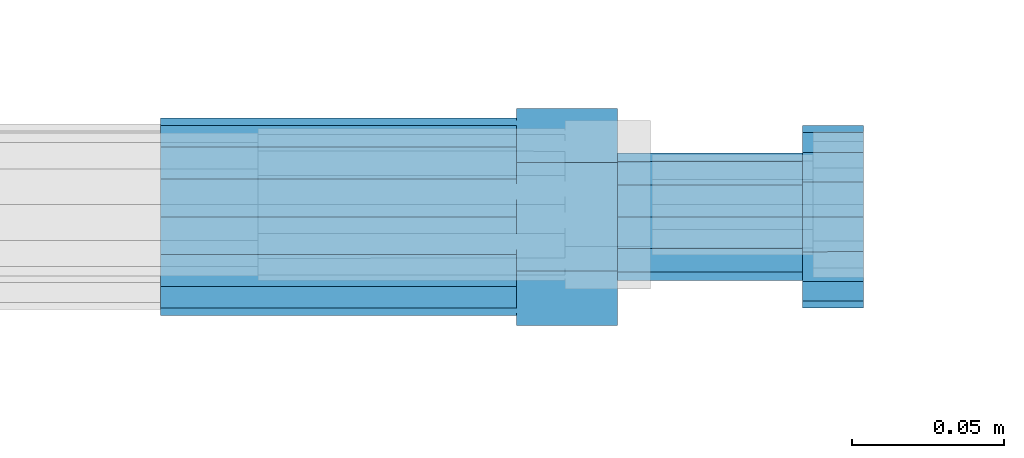
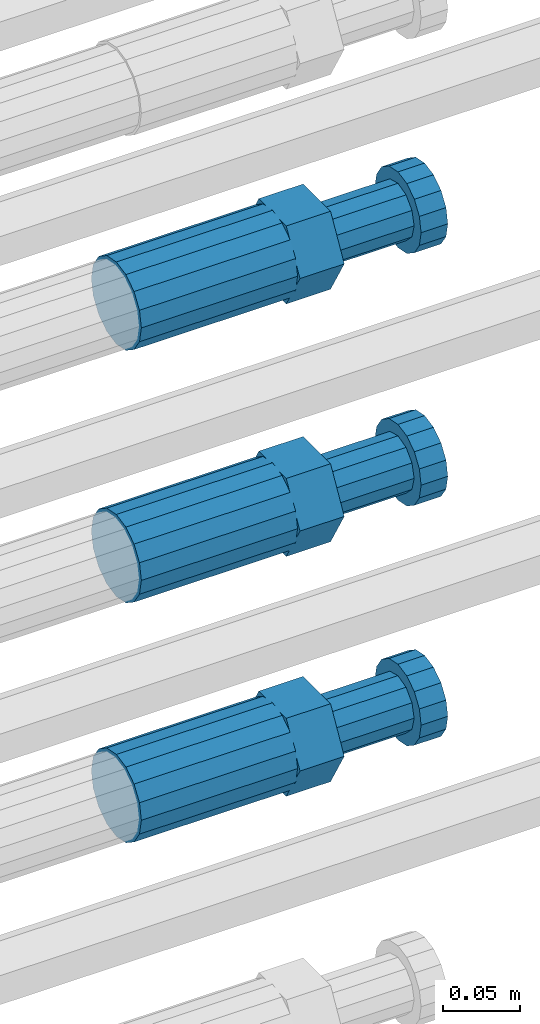
# One storey, part 113 of 119: 3 beams.
"""IFC2X3 building model written with IfcOpenShell, lengths in millimetres."""

from ifc_helpers import new_model, si_unit, frame, origin_with_axes, place, context, subcontext, project, spatial, faceted_brep, material, type_object, element, save


model = new_model("IFC2X3")

# Units and contexts
model_context = context("Model", 3, precision=1e-05, world=origin_with_axes())
body_context = subcontext(model_context, "Body", "Model", "MODEL_VIEW")
ifc_project = project(units=[si_unit("LENGTHUNIT", "METRE", prefix="MILLI"), si_unit("AREAUNIT", "SQUARE_METRE"), si_unit("VOLUMEUNIT", "CUBIC_METRE"), si_unit("MASSUNIT", "GRAM", prefix="KILO"), si_unit("TIMEUNIT", "SECOND"), si_unit("PLANEANGLEUNIT", "RADIAN"), si_unit("SOLIDANGLEUNIT", "STERADIAN"), si_unit("THERMODYNAMICTEMPERATUREUNIT", "DEGREE_CELSIUS"), si_unit("LUMINOUSINTENSITYUNIT", "LUMEN")], contexts=[model_context])

# Site, building, storey
site_placement = place(None, origin_with_axes())
site = spatial("IfcSite", under=ifc_project, at=site_placement, CompositionType="ELEMENT")
building_placement = place(site_placement, origin_with_axes())
building = spatial("IfcBuilding", under=site, at=building_placement, Name="Undefined", CompositionType="ELEMENT")
storey_placement = place(building_placement, origin_with_axes())
storey = spatial("IfcBuildingStorey", under=building, at=storey_placement, Name="Undefined", CompositionType="ELEMENT", Elevation=0.0)

# Beams
ifc_material = material(Name="STEEL/S275")
beam_type = type_object("IfcBeamType", Name="ROD65", PredefinedType="NOTDEFINED")
beam_1_placement = place(storey_placement, frame((2038759.02023304, 6206285.47994599, 21639.9894209215), z_axis=(0.0, 0.0, 1.0), x_axis=(1.0, 0.0, 0.0)))
element("IfcBeam", 1, at=beam_1_placement, inside=storey, type_object=beam_type, material=ifc_material, Name="AGB40", ObjectType="ROD65", context=body_context, shape_type="Brep", body=[
    faceted_brep([(116.999999999069, 17.8249999252148, 30.8738056446964), (116.999999998137, 22.0056957420893, 23.632628078838), (116.999999999069, 12.4372115600854, 30.0260848066173), (116.999999999069, 8.17543111252598, 30.8738056446964), (117.000000000931, -17.8250000746921, 30.8738056446964), (150.200000001118, -17.8250000723638, 30.8738056446964), (150.199999999255, 17.8249999275431, 30.8738056446964), (117.000000000931, -8.17543109622784, 30.8738056446964), (117.000000001863, -22.0056959956419, 23.6326278985034), (117.000000000931, -12.4372115437873, 30.0260848066173), (117.000000001863, -35.6500000746455, -2.18278728425503e-10), (150.200000002049, -35.6500000723172, -2.18278728425503e-10), (117.000000001863, -30.8443149488885, 8.32369080289209), (117.000000001863, -30.8443149488885, -8.32369080355784), (117.000000002794, -32.4999999918509, 0.0), (117.000000000931, -17.8250000746921, -30.873805645133), (150.200000001118, -17.8250000723638, -30.873805645133), (117.000000001863, -22.0056959961075, -23.6326278982269), (117.000000000931, -8.17543109389953, -30.873805645133), (117.000000000931, -12.4372115437873, -30.0260848066173), (116.999999999069, 17.8249999252148, -30.873805645133), (150.199999999255, 17.8249999275431, -30.873805645133), (116.999999999069, 8.17543111019768, -30.873805645133), (116.999999999069, 12.4372115600854, -30.0260848066173), (116.999999998137, 22.005695742555, -23.6326280785652), (116.999999998137, 35.6499999251682, -2.18278728425503e-10), (150.199999998324, 35.6499999277294, -2.18278728425503e-10), (116.999999998137, 30.8443150522653, -8.32369036550881), (116.999999997206, 32.5000000081491, 0.0), (116.999999998137, 30.8443150522653, 8.32369036483942), (1.86264514923096e-09, -22.9809703885112, 22.9809703885621), (1.86264514923096e-09, -30.0260848065373, 12.4372115518672), (117.000000001863, -30.0260847983882, 12.4372115518672), (117.000000001863, -22.9809703803621, 22.9809703885621), (-1.86264514923096e-09, 22.9809703885112, -22.9809703885621), (-1.86264514923096e-09, 30.0260848065373, -12.4372115518672), (116.999999998137, 30.0260848146863, -12.4372115518672), (116.999999998137, 22.9809703966603, -22.9809703885621), (1.86264514923096e-09, -30.0260848065373, -12.4372115518672), (1.86264514923096e-09, -22.9809703885112, -22.9809703885621), (117.000000001863, -22.9809703803621, -22.9809703885621), (117.000000001863, -30.0260847983882, -12.4372115518672), (9.31322574615479e-10, -12.4372115519363, 30.0260848066173), (0.0, 0.0, 32.5), (-9.31322574615479e-10, 12.4372115519363, 30.0260848066173), (-1.86264514923096e-09, 22.9809703885112, 22.9809703885621), (-1.86264514923096e-09, 30.0260848065373, 12.4372115518672), (-2.79396772384644e-09, 32.5, 0.0), (-9.31322574615479e-10, 12.4372115519363, -30.0260848066173), (0.0, 0.0, -32.5), (9.31322574615479e-10, -12.4372115519363, -30.0260848066173), (2.79396772384644e-09, -32.5, 0.0), (116.999999998137, 22.9809703966603, 22.9809703885621), (116.999999998137, 30.0260848146863, 12.4372115518672), (117.0, 8.14907252788544e-09, -32.5), (117.0, 8.14907252788544e-09, 32.5), (150.200000000186, -10.5000000959262, 18.1865334791873), (150.199999999255, -9.59262251853943e-08, 20.9999999997126), (150.199999998324, 10.4999999040738, 18.1865334791873), (150.199999997392, 18.1865333835594, 10.4999999997126), (150.199999997392, 20.9999999040738, -2.87400325760245e-10), (150.199999997392, 18.1865333835594, -10.5000000002874), (150.199999998324, 10.4999999040738, -18.1865334797621), (150.199999999255, -9.59262251853943e-08, -21.0000000002874), (150.200000000186, -10.5000000959262, -18.1865334797621), (150.200000000186, -18.1865335754119, -10.5000000002874), (150.200000001118, -21.0000000959262, -2.87400325760245e-10), (150.200000000186, -18.1865335754119, 10.4999999997126), (210.979999999516, 10.4999999082647, 18.1865334791873), (210.979999999516, -9.17352735996246e-08, 20.9999999997126), (210.979999997653, 18.1865333877504, 10.4999999997126), (210.979999997653, 20.9999999082647, -2.87400325760245e-10), (210.979999997653, 18.1865333877504, -10.5000000002874), (210.979999999516, 10.4999999082647, -18.1865334797621), (210.979999999516, -9.17352735996246e-08, -21.0000000002874), (210.979999999516, -10.5000000917353, -18.1865334797621), (210.980000000447, -18.1865335712209, -10.5000000002874), (210.980000001378, -21.0000000917353, -2.87400325760245e-10), (210.980000000447, -18.1865335712209, 10.4999999997126), (210.979999999516, -10.5000000917353, 18.1865334791873), (211.001368402503, -27.7269939335529, -11.4911163272045), (211.003082515672, -21.2238095656503, -21.2238154190527), (231.002518340945, -21.2131946226582, -21.2132004554769), (231.000804228708, -27.7163789905608, -11.4805013636287), (211.001368415542, -11.4911086384673, -27.7269970399575), (231.000804241747, -11.4804936954752, -27.7163820763781), (210.996487061493, -0.0106066407170147, -30.0106107396168), (230.995922887698, 8.30227509140968e-06, -29.999995776041), (210.98918159306, 11.4698940692469, -27.7269970332745), (230.988617419265, 11.4805090120062, -27.7163820696951), (210.980564201251, 21.2025913291145, -21.2238154067054), (230.980000027455, 21.2132062721066, -21.2132004431296), (210.971946807578, 27.7057702087332, -11.4911163110701), (230.971382633783, 27.7163851517253, -11.4805013474943), (210.964641331695, 29.9893806746695, -0.0106149565435771), (230.9640771579, 29.9999956176616, 7.03221303410828e-09), (210.959759964608, 27.7057637346443, 11.4698863966551), (230.959195790812, 27.7163786776364, 11.4805013602345), (210.958045851439, 21.2025793667417, 21.2025854885032), (230.957481677644, 21.2131943097338, 21.2132004520827), (210.959759951569, 11.4698784395587, 27.705767109408), (230.959195776843, 11.4804933823179, 27.7163820729838), (210.964641305618, -0.0106235581915826, 29.9893808090674), (230.964077131823, -8.61519947648048e-06, 29.9999957726432), (210.971946774051, -11.4911242681555, 27.7057671027251), (230.971382599324, -11.4805093251634, 27.7163820663009), (210.98056416586, -21.2238215280231, 21.2025854761559), (230.979999991134, -21.2132065852638, 21.2132004397354), (210.989181559533, -27.7270004076418, 11.4698863805206), (230.988617384806, -27.7163854646496, 11.4805013441), (210.996487035416, -30.0106108735781, -0.0106149740058754), (230.995922861621, -29.999995930586, -1.04300852399319e-08)], [[[0, 1, 2, 3]], [[4, 5, 6, 0, 3, 7]], [[8, 4, 7, 9]], [[10, 11, 5, 4, 8, 12]], [[13, 10, 12, 14]], [[15, 16, 11, 10, 13, 17]], [[18, 15, 17, 19]], [[20, 21, 16, 15, 18, 22]], [[20, 22, 23, 24]], [[25, 26, 21, 20, 24, 27]], [[25, 27, 28, 29]], [[30, 31, 32, 33]], [[34, 35, 36, 37]], [[38, 39, 40, 41]], [[31, 30, 42, 43, 44, 45, 46, 47, 35, 34, 48, 49, 50, 39, 38, 51]], [[46, 45, 52, 53]], [[28, 47, 46, 53, 29]], [[27, 36, 35, 47, 28]], [[24, 37, 36, 27]], [[23, 48, 34, 37, 24]], [[22, 54, 49, 48, 23]], [[18, 54, 22]], [[19, 50, 49, 54, 18]], [[17, 40, 39, 50, 19]], [[13, 41, 40, 17]], [[14, 51, 38, 41, 13]], [[12, 32, 31, 51, 14]], [[8, 33, 32, 12]], [[9, 42, 30, 33, 8]], [[7, 55, 43, 42, 9]], [[3, 55, 7]], [[2, 44, 43, 55, 3]], [[1, 52, 45, 44, 2]], [[29, 53, 52, 1]], [[0, 6, 26, 25, 29, 1]], [[5, 11, 16, 21, 26, 6], [56, 57, 58, 59, 60, 61, 62, 63, 64, 65, 66, 67]], [[68, 58, 57, 69]], [[70, 59, 58, 68]], [[71, 60, 59, 70]], [[72, 61, 60, 71]], [[73, 62, 61, 72]], [[74, 63, 62, 73]], [[75, 64, 63, 74]], [[76, 65, 64, 75]], [[77, 66, 65, 76]], [[78, 67, 66, 77]], [[79, 56, 67, 78]], [[69, 57, 56, 79]], [[80, 81, 82, 83]], [[81, 84, 85, 82]], [[84, 86, 87, 85]], [[86, 88, 89, 87]], [[88, 90, 91, 89]], [[90, 92, 93, 91]], [[92, 94, 95, 93]], [[94, 96, 97, 95]], [[96, 98, 99, 97]], [[98, 100, 101, 99]], [[100, 102, 103, 101]], [[102, 104, 105, 103]], [[104, 106, 107, 105]], [[106, 108, 109, 107]], [[108, 110, 111, 109]], [[82, 85, 87, 89, 91, 93, 95, 97, 99, 101, 103, 105, 107, 109, 111, 83]], [[110, 80, 83, 111]], [[108, 106, 104, 102, 100, 98, 96, 94, 92, 90, 88, 86, 84, 81, 80, 110], [78, 77, 76, 75, 74, 73, 72, 71, 70, 68, 69, 79]]]),
])
beam_2_placement = place(storey_placement, frame((2038759.02023304, 6206285.47994599, 21439.9894209215), z_axis=(0.0, 0.0, 1.0), x_axis=(1.0, 0.0, 0.0)))
element("IfcBeam", 2, at=beam_2_placement, inside=storey, type_object=beam_type, material=ifc_material, Name="AGB40", ObjectType="ROD65", context=body_context, shape_type="Brep", body=[
    faceted_brep([(116.999999999069, 17.8249999252148, 30.8738056446964), (116.999999998137, 22.0056957420893, 23.632628078838), (116.999999999069, 12.4372115600854, 30.0260848066173), (116.999999999069, 8.17543111252598, 30.8738056446964), (117.000000000931, -17.8250000746921, 30.8738056446964), (150.200000001118, -17.8250000723638, 30.8738056446964), (150.199999999255, 17.8249999275431, 30.8738056446964), (117.000000000931, -8.17543109622784, 30.8738056446964), (117.000000001863, -22.0056959956419, 23.6326278985034), (117.000000000931, -12.4372115437873, 30.0260848066173), (117.000000001863, -35.6500000746455, -2.18278728425503e-10), (150.200000002049, -35.6500000723172, -2.18278728425503e-10), (117.000000001863, -30.8443149488885, 8.32369080289209), (117.000000001863, -30.8443149488885, -8.32369080355784), (117.000000002794, -32.4999999918509, 0.0), (117.000000000931, -17.8250000746921, -30.873805645133), (150.200000001118, -17.8250000723638, -30.873805645133), (117.000000001863, -22.0056959961075, -23.6326278982269), (117.000000000931, -8.17543109389953, -30.873805645133), (117.000000000931, -12.4372115437873, -30.0260848066173), (116.999999999069, 17.8249999252148, -30.873805645133), (150.199999999255, 17.8249999275431, -30.873805645133), (116.999999999069, 8.17543111019768, -30.873805645133), (116.999999999069, 12.4372115600854, -30.0260848066173), (116.999999998137, 22.005695742555, -23.6326280785652), (116.999999998137, 35.6499999251682, -2.18278728425503e-10), (150.199999998324, 35.6499999277294, -2.18278728425503e-10), (116.999999998137, 30.8443150522653, -8.32369036550881), (116.999999997206, 32.5000000081491, 0.0), (116.999999998137, 30.8443150522653, 8.32369036483942), (1.86264514923096e-09, -22.9809703885112, 22.9809703885621), (1.86264514923096e-09, -30.0260848065373, 12.4372115518672), (117.000000001863, -30.0260847983882, 12.4372115518672), (117.000000001863, -22.9809703803621, 22.9809703885621), (-1.86264514923096e-09, 22.9809703885112, -22.9809703885621), (-1.86264514923096e-09, 30.0260848065373, -12.4372115518672), (116.999999998137, 30.0260848146863, -12.4372115518672), (116.999999998137, 22.9809703966603, -22.9809703885621), (1.86264514923096e-09, -30.0260848065373, -12.4372115518672), (1.86264514923096e-09, -22.9809703885112, -22.9809703885621), (117.000000001863, -22.9809703803621, -22.9809703885621), (117.000000001863, -30.0260847983882, -12.4372115518672), (9.31322574615479e-10, -12.4372115519363, 30.0260848066173), (0.0, 0.0, 32.5), (-9.31322574615479e-10, 12.4372115519363, 30.0260848066173), (-1.86264514923096e-09, 22.9809703885112, 22.9809703885621), (-1.86264514923096e-09, 30.0260848065373, 12.4372115518672), (-2.79396772384644e-09, 32.5, 0.0), (-9.31322574615479e-10, 12.4372115519363, -30.0260848066173), (0.0, 0.0, -32.5), (9.31322574615479e-10, -12.4372115519363, -30.0260848066173), (2.79396772384644e-09, -32.5, 0.0), (116.999999998137, 22.9809703966603, 22.9809703885621), (116.999999998137, 30.0260848146863, 12.4372115518672), (117.0, 8.14907252788544e-09, -32.5), (117.0, 8.14907252788544e-09, 32.5), (150.200000000186, -10.5000000959262, 18.1865334791873), (150.199999999255, -9.59262251853943e-08, 20.9999999997126), (150.199999998324, 10.4999999040738, 18.1865334791873), (150.199999997392, 18.1865333835594, 10.4999999997126), (150.199999997392, 20.9999999040738, -2.87400325760245e-10), (150.199999997392, 18.1865333835594, -10.5000000002874), (150.199999998324, 10.4999999040738, -18.1865334797621), (150.199999999255, -9.59262251853943e-08, -21.0000000002874), (150.200000000186, -10.5000000959262, -18.1865334797621), (150.200000000186, -18.1865335754119, -10.5000000002874), (150.200000001118, -21.0000000959262, -2.87400325760245e-10), (150.200000000186, -18.1865335754119, 10.4999999997126), (210.979999999516, 10.4999999082647, 18.1865334791873), (210.979999999516, -9.17352735996246e-08, 20.9999999997126), (210.979999997653, 18.1865333877504, 10.4999999997126), (210.979999997653, 20.9999999082647, -2.87400325760245e-10), (210.979999997653, 18.1865333877504, -10.5000000002874), (210.979999999516, 10.4999999082647, -18.1865334797621), (210.979999999516, -9.17352735996246e-08, -21.0000000002874), (210.979999999516, -10.5000000917353, -18.1865334797621), (210.980000000447, -18.1865335712209, -10.5000000002874), (210.980000001378, -21.0000000917353, -2.87400325760245e-10), (210.980000000447, -18.1865335712209, 10.4999999997126), (210.979999999516, -10.5000000917353, 18.1865334791873), (211.001368402503, -27.7269939335529, -11.4911163272045), (211.003082515672, -21.2238095656503, -21.2238154190527), (231.002518340945, -21.2131946226582, -21.2132004554769), (231.000804228708, -27.7163789905608, -11.4805013636287), (211.001368415542, -11.4911086384673, -27.7269970399575), (231.000804241747, -11.4804936954752, -27.7163820763781), (210.996487061493, -0.0106066407170147, -30.0106107396168), (230.995922887698, 8.30227509140968e-06, -29.999995776041), (210.98918159306, 11.4698940692469, -27.7269970332745), (230.988617419265, 11.4805090120062, -27.7163820696951), (210.980564201251, 21.2025913291145, -21.2238154067054), (230.980000027455, 21.2132062721066, -21.2132004431296), (210.971946807578, 27.7057702087332, -11.4911163110701), (230.971382633783, 27.7163851517253, -11.4805013474943), (210.964641331695, 29.9893806746695, -0.0106149565435771), (230.9640771579, 29.9999956176616, 7.03221303410828e-09), (210.959759964608, 27.7057637346443, 11.4698863966551), (230.959195790812, 27.7163786776364, 11.4805013602345), (210.958045851439, 21.2025793667417, 21.2025854885032), (230.957481677644, 21.2131943097338, 21.2132004520827), (210.959759951569, 11.4698784395587, 27.705767109408), (230.959195776843, 11.4804933823179, 27.7163820729838), (210.964641305618, -0.0106235581915826, 29.9893808090674), (230.964077131823, -8.61519947648048e-06, 29.9999957726432), (210.971946774051, -11.4911242681555, 27.7057671027251), (230.971382599324, -11.4805093251634, 27.7163820663009), (210.98056416586, -21.2238215280231, 21.2025854761559), (230.979999991134, -21.2132065852638, 21.2132004397354), (210.989181559533, -27.7270004076418, 11.4698863805206), (230.988617384806, -27.7163854646496, 11.4805013441), (210.996487035416, -30.0106108735781, -0.0106149740058754), (230.995922861621, -29.999995930586, -1.04300852399319e-08)], [[[0, 1, 2, 3]], [[4, 5, 6, 0, 3, 7]], [[8, 4, 7, 9]], [[10, 11, 5, 4, 8, 12]], [[13, 10, 12, 14]], [[15, 16, 11, 10, 13, 17]], [[18, 15, 17, 19]], [[20, 21, 16, 15, 18, 22]], [[20, 22, 23, 24]], [[25, 26, 21, 20, 24, 27]], [[25, 27, 28, 29]], [[30, 31, 32, 33]], [[34, 35, 36, 37]], [[38, 39, 40, 41]], [[31, 30, 42, 43, 44, 45, 46, 47, 35, 34, 48, 49, 50, 39, 38, 51]], [[46, 45, 52, 53]], [[28, 47, 46, 53, 29]], [[27, 36, 35, 47, 28]], [[24, 37, 36, 27]], [[23, 48, 34, 37, 24]], [[22, 54, 49, 48, 23]], [[18, 54, 22]], [[19, 50, 49, 54, 18]], [[17, 40, 39, 50, 19]], [[13, 41, 40, 17]], [[14, 51, 38, 41, 13]], [[12, 32, 31, 51, 14]], [[8, 33, 32, 12]], [[9, 42, 30, 33, 8]], [[7, 55, 43, 42, 9]], [[3, 55, 7]], [[2, 44, 43, 55, 3]], [[1, 52, 45, 44, 2]], [[29, 53, 52, 1]], [[0, 6, 26, 25, 29, 1]], [[5, 11, 16, 21, 26, 6], [56, 57, 58, 59, 60, 61, 62, 63, 64, 65, 66, 67]], [[68, 58, 57, 69]], [[70, 59, 58, 68]], [[71, 60, 59, 70]], [[72, 61, 60, 71]], [[73, 62, 61, 72]], [[74, 63, 62, 73]], [[75, 64, 63, 74]], [[76, 65, 64, 75]], [[77, 66, 65, 76]], [[78, 67, 66, 77]], [[79, 56, 67, 78]], [[69, 57, 56, 79]], [[80, 81, 82, 83]], [[81, 84, 85, 82]], [[84, 86, 87, 85]], [[86, 88, 89, 87]], [[88, 90, 91, 89]], [[90, 92, 93, 91]], [[92, 94, 95, 93]], [[94, 96, 97, 95]], [[96, 98, 99, 97]], [[98, 100, 101, 99]], [[100, 102, 103, 101]], [[102, 104, 105, 103]], [[104, 106, 107, 105]], [[106, 108, 109, 107]], [[108, 110, 111, 109]], [[82, 85, 87, 89, 91, 93, 95, 97, 99, 101, 103, 105, 107, 109, 111, 83]], [[110, 80, 83, 111]], [[108, 106, 104, 102, 100, 98, 96, 94, 92, 90, 88, 86, 84, 81, 80, 110], [78, 77, 76, 75, 74, 73, 72, 71, 70, 68, 69, 79]]]),
])
beam_3_placement = place(storey_placement, frame((2038759.02023304, 6206285.47994599, 21249.9894209215), z_axis=(0.0, 0.0, 1.0), x_axis=(1.0, 0.0, 0.0)))
element("IfcBeam", 3, at=beam_3_placement, inside=storey, type_object=beam_type, material=ifc_material, Name="AGB40", ObjectType="ROD65", context=body_context, shape_type="Brep", body=[
    faceted_brep([(116.999999999069, 17.8249999252148, 30.8738056446964), (116.999999998137, 22.0056957420893, 23.632628078838), (116.999999999069, 12.4372115600854, 30.0260848066173), (116.999999999069, 8.17543111252598, 30.8738056446964), (117.000000000931, -17.8250000746921, 30.8738056446964), (150.200000001118, -17.8250000723638, 30.8738056446964), (150.199999999255, 17.8249999275431, 30.8738056446964), (117.000000000931, -8.17543109622784, 30.8738056446964), (117.000000001863, -22.0056959956419, 23.6326278985034), (117.000000000931, -12.4372115437873, 30.0260848066173), (117.000000001863, -35.6500000746455, -2.18278728425503e-10), (150.200000002049, -35.6500000723172, -2.18278728425503e-10), (117.000000001863, -30.8443149488885, 8.32369080289209), (117.000000001863, -30.8443149488885, -8.32369080355784), (117.000000002794, -32.4999999918509, 0.0), (117.000000000931, -17.8250000746921, -30.873805645133), (150.200000001118, -17.8250000723638, -30.873805645133), (117.000000001863, -22.0056959961075, -23.6326278982269), (117.000000000931, -8.17543109389953, -30.873805645133), (117.000000000931, -12.4372115437873, -30.0260848066173), (116.999999999069, 17.8249999252148, -30.873805645133), (150.199999999255, 17.8249999275431, -30.873805645133), (116.999999999069, 8.17543111019768, -30.873805645133), (116.999999999069, 12.4372115600854, -30.0260848066173), (116.999999998137, 22.005695742555, -23.6326280785652), (116.999999998137, 35.6499999251682, -2.18278728425503e-10), (150.199999998324, 35.6499999277294, -2.18278728425503e-10), (116.999999998137, 30.8443150522653, -8.32369036550881), (116.999999997206, 32.5000000081491, 0.0), (116.999999998137, 30.8443150522653, 8.32369036483942), (1.86264514923096e-09, -22.9809703885112, 22.9809703885621), (1.86264514923096e-09, -30.0260848065373, 12.4372115518672), (117.000000001863, -30.0260847983882, 12.4372115518672), (117.000000001863, -22.9809703803621, 22.9809703885621), (-1.86264514923096e-09, 22.9809703885112, -22.9809703885621), (-1.86264514923096e-09, 30.0260848065373, -12.4372115518672), (116.999999998137, 30.0260848146863, -12.4372115518672), (116.999999998137, 22.9809703966603, -22.9809703885621), (1.86264514923096e-09, -30.0260848065373, -12.4372115518672), (1.86264514923096e-09, -22.9809703885112, -22.9809703885621), (117.000000001863, -22.9809703803621, -22.9809703885621), (117.000000001863, -30.0260847983882, -12.4372115518672), (9.31322574615479e-10, -12.4372115519363, 30.0260848066173), (0.0, 0.0, 32.5), (-9.31322574615479e-10, 12.4372115519363, 30.0260848066173), (-1.86264514923096e-09, 22.9809703885112, 22.9809703885621), (-1.86264514923096e-09, 30.0260848065373, 12.4372115518672), (-2.79396772384644e-09, 32.5, 0.0), (-9.31322574615479e-10, 12.4372115519363, -30.0260848066173), (0.0, 0.0, -32.5), (9.31322574615479e-10, -12.4372115519363, -30.0260848066173), (2.79396772384644e-09, -32.5, 0.0), (116.999999998137, 22.9809703966603, 22.9809703885621), (116.999999998137, 30.0260848146863, 12.4372115518672), (117.0, 8.14907252788544e-09, -32.5), (117.0, 8.14907252788544e-09, 32.5), (150.200000000186, -10.5000000959262, 18.1865334791873), (150.199999999255, -9.59262251853943e-08, 20.9999999997126), (150.199999998324, 10.4999999040738, 18.1865334791873), (150.199999997392, 18.1865333835594, 10.4999999997126), (150.199999997392, 20.9999999040738, -2.87400325760245e-10), (150.199999997392, 18.1865333835594, -10.5000000002874), (150.199999998324, 10.4999999040738, -18.1865334797621), (150.199999999255, -9.59262251853943e-08, -21.0000000002874), (150.200000000186, -10.5000000959262, -18.1865334797621), (150.200000000186, -18.1865335754119, -10.5000000002874), (150.200000001118, -21.0000000959262, -2.87400325760245e-10), (150.200000000186, -18.1865335754119, 10.4999999997126), (210.979999999516, 10.4999999082647, 18.1865334791873), (210.979999999516, -9.17352735996246e-08, 20.9999999997126), (210.979999997653, 18.1865333877504, 10.4999999997126), (210.979999997653, 20.9999999082647, -2.87400325760245e-10), (210.979999997653, 18.1865333877504, -10.5000000002874), (210.979999999516, 10.4999999082647, -18.1865334797621), (210.979999999516, -9.17352735996246e-08, -21.0000000002874), (210.979999999516, -10.5000000917353, -18.1865334797621), (210.980000000447, -18.1865335712209, -10.5000000002874), (210.980000001378, -21.0000000917353, -2.87400325760245e-10), (210.980000000447, -18.1865335712209, 10.4999999997126), (210.979999999516, -10.5000000917353, 18.1865334791873), (211.001368402503, -27.7269939335529, -11.4911163272045), (211.003082515672, -21.2238095656503, -21.2238154190527), (231.002518340945, -21.2131946226582, -21.2132004554769), (231.000804228708, -27.7163789905608, -11.4805013636287), (211.001368415542, -11.4911086384673, -27.7269970399575), (231.000804241747, -11.4804936954752, -27.7163820763781), (210.996487061493, -0.0106066407170147, -30.0106107396168), (230.995922887698, 8.30227509140968e-06, -29.999995776041), (210.98918159306, 11.4698940692469, -27.7269970332745), (230.988617419265, 11.4805090120062, -27.7163820696951), (210.980564201251, 21.2025913291145, -21.2238154067054), (230.980000027455, 21.2132062721066, -21.2132004431296), (210.971946807578, 27.7057702087332, -11.4911163110701), (230.971382633783, 27.7163851517253, -11.4805013474943), (210.964641331695, 29.9893806746695, -0.0106149565435771), (230.9640771579, 29.9999956176616, 7.03221303410828e-09), (210.959759964608, 27.7057637346443, 11.4698863966551), (230.959195790812, 27.7163786776364, 11.4805013602345), (210.958045851439, 21.2025793667417, 21.2025854885032), (230.957481677644, 21.2131943097338, 21.2132004520827), (210.959759951569, 11.4698784395587, 27.705767109408), (230.959195776843, 11.4804933823179, 27.7163820729838), (210.964641305618, -0.0106235581915826, 29.9893808090674), (230.964077131823, -8.61519947648048e-06, 29.9999957726432), (210.971946774051, -11.4911242681555, 27.7057671027251), (230.971382599324, -11.4805093251634, 27.7163820663009), (210.98056416586, -21.2238215280231, 21.2025854761559), (230.979999991134, -21.2132065852638, 21.2132004397354), (210.989181559533, -27.7270004076418, 11.4698863805206), (230.988617384806, -27.7163854646496, 11.4805013441), (210.996487035416, -30.0106108735781, -0.0106149740058754), (230.995922861621, -29.999995930586, -1.04300852399319e-08)], [[[0, 1, 2, 3]], [[4, 5, 6, 0, 3, 7]], [[8, 4, 7, 9]], [[10, 11, 5, 4, 8, 12]], [[13, 10, 12, 14]], [[15, 16, 11, 10, 13, 17]], [[18, 15, 17, 19]], [[20, 21, 16, 15, 18, 22]], [[20, 22, 23, 24]], [[25, 26, 21, 20, 24, 27]], [[25, 27, 28, 29]], [[30, 31, 32, 33]], [[34, 35, 36, 37]], [[38, 39, 40, 41]], [[31, 30, 42, 43, 44, 45, 46, 47, 35, 34, 48, 49, 50, 39, 38, 51]], [[46, 45, 52, 53]], [[28, 47, 46, 53, 29]], [[27, 36, 35, 47, 28]], [[24, 37, 36, 27]], [[23, 48, 34, 37, 24]], [[22, 54, 49, 48, 23]], [[18, 54, 22]], [[19, 50, 49, 54, 18]], [[17, 40, 39, 50, 19]], [[13, 41, 40, 17]], [[14, 51, 38, 41, 13]], [[12, 32, 31, 51, 14]], [[8, 33, 32, 12]], [[9, 42, 30, 33, 8]], [[7, 55, 43, 42, 9]], [[3, 55, 7]], [[2, 44, 43, 55, 3]], [[1, 52, 45, 44, 2]], [[29, 53, 52, 1]], [[0, 6, 26, 25, 29, 1]], [[5, 11, 16, 21, 26, 6], [56, 57, 58, 59, 60, 61, 62, 63, 64, 65, 66, 67]], [[68, 58, 57, 69]], [[70, 59, 58, 68]], [[71, 60, 59, 70]], [[72, 61, 60, 71]], [[73, 62, 61, 72]], [[74, 63, 62, 73]], [[75, 64, 63, 74]], [[76, 65, 64, 75]], [[77, 66, 65, 76]], [[78, 67, 66, 77]], [[79, 56, 67, 78]], [[69, 57, 56, 79]], [[80, 81, 82, 83]], [[81, 84, 85, 82]], [[84, 86, 87, 85]], [[86, 88, 89, 87]], [[88, 90, 91, 89]], [[90, 92, 93, 91]], [[92, 94, 95, 93]], [[94, 96, 97, 95]], [[96, 98, 99, 97]], [[98, 100, 101, 99]], [[100, 102, 103, 101]], [[102, 104, 105, 103]], [[104, 106, 107, 105]], [[106, 108, 109, 107]], [[108, 110, 111, 109]], [[82, 85, 87, 89, 91, 93, 95, 97, 99, 101, 103, 105, 107, 109, 111, 83]], [[110, 80, 83, 111]], [[108, 106, 104, 102, 100, 98, 96, 94, 92, 90, 88, 86, 84, 81, 80, 110], [78, 77, 76, 75, 74, 73, 72, 71, 70, 68, 69, 79]]]),
])

save(model, "model.ifc")
